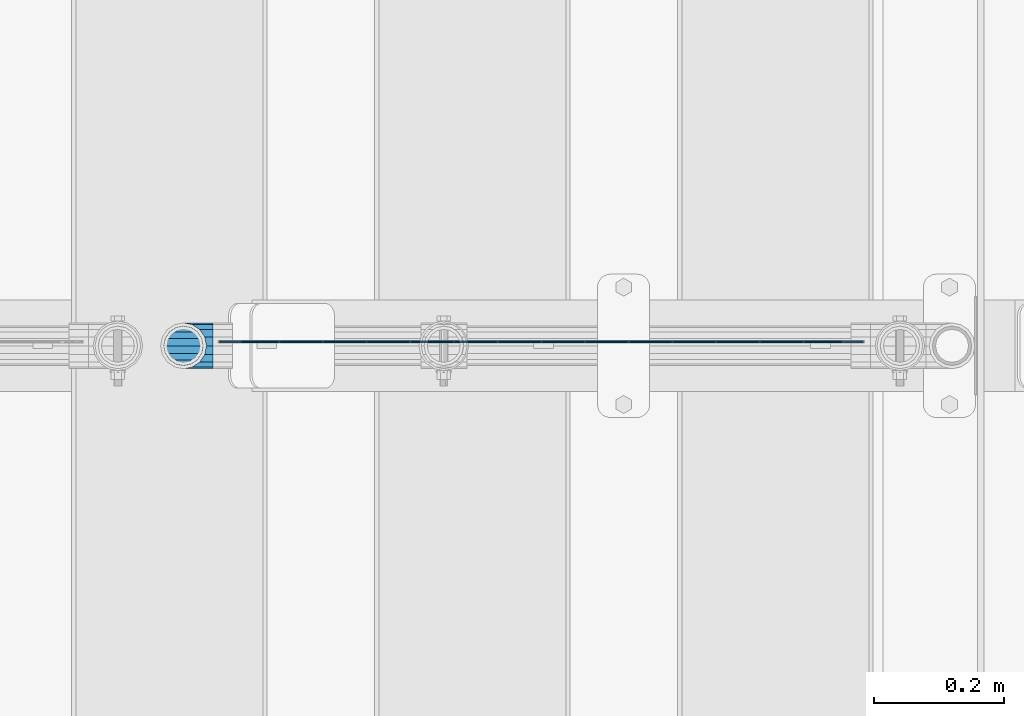
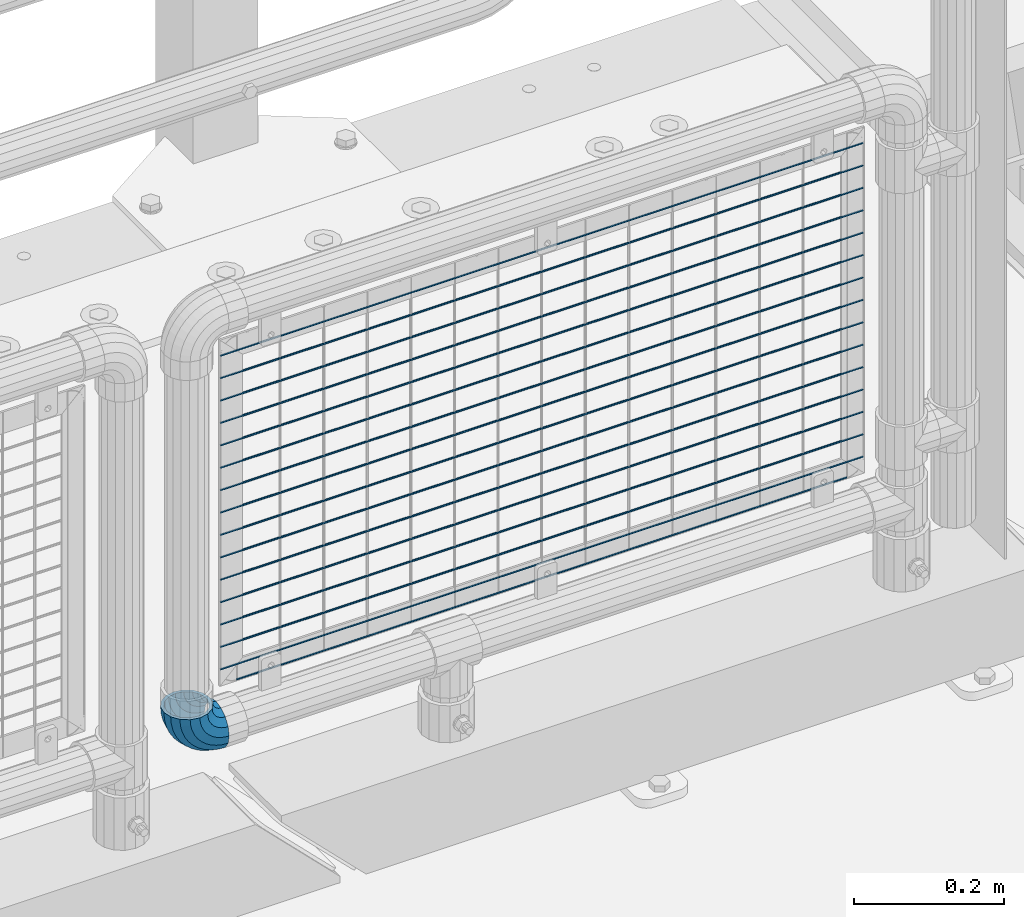
# One storey, part 168 of 247: 16 beams, 1 member.
"""IFC2X3 building model written with IfcOpenShell, lengths in millimetres."""

from ifc_helpers import new_model, si_unit, frame, origin_with_axes, place, context, subcontext, project, spatial, faceted_brep, material, type_object, element, save


model = new_model("IFC2X3")

# Units and contexts
model_context = context("Model", 3, precision=1e-05, world=origin_with_axes())
body_context = subcontext(model_context, "Body", "Model", "MODEL_VIEW")
ifc_project = project(units=[si_unit("LENGTHUNIT", "METRE", prefix="MILLI"), si_unit("AREAUNIT", "SQUARE_METRE"), si_unit("VOLUMEUNIT", "CUBIC_METRE"), si_unit("MASSUNIT", "GRAM", prefix="KILO"), si_unit("TIMEUNIT", "SECOND"), si_unit("PLANEANGLEUNIT", "RADIAN"), si_unit("SOLIDANGLEUNIT", "STERADIAN"), si_unit("THERMODYNAMICTEMPERATUREUNIT", "DEGREE_CELSIUS"), si_unit("LUMINOUSINTENSITYUNIT", "LUMEN")], contexts=[model_context])

# Site, building, storey
site_placement = place(None, origin_with_axes())
site = spatial("IfcSite", under=ifc_project, at=site_placement, CompositionType="ELEMENT")
building_placement = place(site_placement, origin_with_axes())
building = spatial("IfcBuilding", under=site, at=building_placement, Name="Standard", CompositionType="ELEMENT")
storey_placement = place(building_placement, origin_with_axes())
storey = spatial("IfcBuildingStorey", under=building, at=storey_placement, Name="Undefined", CompositionType="ELEMENT", Elevation=0.0)

# Member
ifc_material = material(Name="Misc_Undefined")
member_type = type_object("IfcMemberType", PredefinedType="NOTDEFINED")
member_placement = place(storey_placement, frame((15121.61, 7664.5, 343.170000000002), z_axis=(-0.707106773186475, 4.52999999771556e-07, -0.707106789186475), x_axis=(0.707106845186484, -4.15000000539602e-07, -0.707106717186484)))
element("IfcMember", 1, at=member_placement, inside=storey, type_object=member_type, material=ifc_material, context=body_context, shape_type="Brep", body=[
    faceted_brep([(0.0, -35.1499999999996, 0.0), (9.51152146007007, -32.4743655677721, -9.51152146007007), (13.2759578763416, -32.4743655677721, -6.29638902527768), (5.36946880023424, -35.1499999999996, 4.58595959347804), (17.5750000000007, -24.8548033587067, -17.5750000000007), (19.9787556631127, -24.8548033587067, -15.5219987155633), (22.9628441077039, -13.4513226476329, -22.962844107702), (24.4574219585265, -13.4513226476329, -21.6863540323957), (24.8548033587067, 0.0, -24.8548033587067), (26.0301204183143, 0.0, -23.8509877588021), (22.9628441077039, 13.4513226476329, -22.962844107702), (24.4574219585265, 13.4513226476329, -21.6863540323957), (17.5750000000007, 24.8548033587067, -17.5750000000007), (19.9787556631127, 24.8548033587067, -15.5219987155633), (9.51152146007007, 32.4743655677721, -9.51152146007007), (13.2759578763416, 32.4743655677721, -6.29638902527768), (0.0, 35.1499999999996, 0.0), (5.36946880023424, 35.1499999999996, 4.58595959347804), (-9.51152146007007, 32.4743655677721, 9.51152146007007), (-2.53702027587133, 32.4743655677721, 15.4683082122338), (-17.5749999999989, 24.8548033587067, 17.5749999999989), (-9.23981806264237, 24.8548033587067, 24.6939179025194), (-22.962844107702, 13.4513226476329, 22.962844107702), (-13.718484358058, 13.4513226476329, 30.8582732193499), (-24.8548033587067, 0.0, 24.8548033587067), (-15.2911828178458, 0.0, 33.0229069457564), (-22.962844107702, -13.4513226476329, 22.962844107702), (-13.718484358058, -13.4513226476329, 30.8582732193499), (-17.5749999999989, -24.8548033587067, 17.5749999999989), (-9.23981806264237, -24.8548033587067, 24.6939179025194), (-9.51152146007007, -32.4743655677721, 9.51152146007007), (-2.53702027587133, -32.4743655677721, 15.4683082122338), (0.0, -30.3500000000004, 0.0), (-8.21265081971796, -28.0397438117179, 8.21265081971796), (-1.45732902223608, -28.0397438117179, 13.9822406910371), (5.36946880023424, -30.3500000000004, 4.58595959347804), (-15.1749999999993, -21.4606908090118, 15.1749999999993), (-7.24480876131202, -21.4606908090118, 21.948023168994), (-19.8270929919981, -11.6144421722802, 19.827092992), (-11.1118790903529, -11.6144421722802, 27.2705888550772), (-21.4606908090118, 0.0, 21.4606908090118), (-12.4698136068437, 0.0, 29.139625372758), (-19.8270929919981, 11.6144421722802, 19.827092992), (-11.1118790903529, 11.6144421722802, 27.2705888550772), (-15.1749999999993, 21.4606908090118, 15.1749999999993), (-7.24480876131202, 21.4606908090118, 21.948023168994), (-8.21265081971796, 28.0397438117179, 8.21265081971796), (-1.45732902223608, 28.0397438117179, 13.9822406910371), (0.0, 30.3500000000004, 0.0), (5.36946880023424, 30.3500000000004, 4.58595959347804), (8.21265081971978, 28.0397438117179, -8.21265081971796), (12.1962666227046, 28.0397438117179, -4.81032150408282), (15.1750000000011, 21.4606908090118, -15.1750000000011), (17.9837463617787, 21.4606908090118, -12.776103982038), (19.827092992, 11.6144421722802, -19.827092992), (21.8508166908214, 11.6144421722802, -18.0986696681211), (21.4606908090118, 0.0, -21.4606908090118), (23.2087512073122, 0.0, -19.9677061858038), (19.827092992, -11.6144421722802, -19.827092992), (21.8508166908214, -11.6144421722802, -18.0986696681211), (15.1750000000011, -21.4606908090118, -15.1750000000011), (17.9837463617787, -21.4606908090118, -12.776103982038), (8.21265081971978, -28.0397438117179, -8.21265081971796), (12.1962666227046, -28.0397438117179, -4.81032150408282), (17.4970053560719, -32.4743655677721, -3.70972780292141), (11.3902326651169, -35.1499999999996, 8.27548843508157), (22.6740772628636, -24.8548033587067, -13.8703035149447), (26.1332861179544, -13.4513226476329, -20.6593831546816), (27.347998730962, 0.0, -23.0433908901377), (26.1332861179544, 13.4513226476329, -20.6593831546816), (22.6740772628636, 24.8548033587067, -13.8703035149447), (17.4970053560719, 32.4743655677721, -3.70972780292141), (11.3902326651169, 35.1499999999996, 8.27548843508157), (5.28345997416, 32.4743655677721, 20.2607046730845), (0.106388067368243, 24.8548033587067, 30.4212803851096), (-3.3528207877207, 13.4513226476329, 37.2103600248429), (-4.56753340072828, 0.0, 39.5943677603027), (-3.3528207877207, -13.4513226476329, 37.2103600248429), (0.106388067368243, -24.8548033587067, 30.4212803851096), (5.28345997416, -32.4743655677721, 20.2607046730845), (6.11738625912767, -28.0397438117179, 18.6240321853929), (11.3902326651169, -30.3500000000004, 8.27548843508157), (1.64728291997744, -21.4606908090118, 27.3971039594999), (-1.33954464053386, -11.6144421722802, 33.2590831078905), (-2.38837900197905, 0.0, 35.3175364441977), (-1.33954464053386, 11.6144421722802, 33.2590831078905), (1.64728291997744, 21.4606908090118, 27.3971039594999), (6.11738625912767, 28.0397438117179, 18.6240321853929), (11.3902326651169, 30.3500000000004, 8.27548843508157), (16.663079071106, 28.0397438117179, -2.07305531522979), (21.1331824102544, 21.4606908090118, -10.8461270893367), (24.1200099707676, 11.6144421722802, -16.7081062377292), (25.1688443322109, 0.0, -18.7665595740345), (24.1200099707676, -11.6144421722802, -16.7081062377292), (21.1331824102544, -21.4606908090118, -10.8461270893367), (16.663079071106, -28.0397438117179, -2.07305531522979), (22.0707277014626, -32.4743655677721, -1.81522997693355), (17.9140404065238, -35.1499999999996, 10.9777380798878), (25.5945970362118, -24.8548033587067, -12.6605846156472), (27.9491712485105, -13.4513226476329, -19.9072189058952), (28.7759877588032, 0.0, -22.4518984678889), (27.9491712485105, 13.4513226476329, -19.9072189058952), (25.5945970362118, 24.8548033587067, -12.6605846156472), (22.0707277014626, 32.4743655677721, -1.81522997693355), (17.9140404065238, 35.1499999999996, 10.9777380798878), (13.757353111585, 32.4743655677721, 23.7707061367073), (10.2334837768358, 24.8548033587067, 34.6160607754209), (7.87890956453703, 13.4513226476329, 41.8626950656671), (7.05209305424432, 0.0, 44.4073746276608), (7.87890956453703, -13.4513226476329, 41.8626950656671), (10.2334837768358, -24.8548033587067, 34.6160607754209), (13.757353111585, -32.4743655677721, 23.7707061367073), (14.3249803951039, -28.0397438117179, 22.0237289909692), (17.9140404065238, -30.3500000000004, 10.9777380798878), (11.2823222355109, -21.4606908090118, 31.3880679179929), (9.24928305078174, -11.6144421722802, 37.6451191472679), (8.53537462724307, 0.0, 39.8423033494455), (9.24928305078174, 11.6144421722802, 37.6451191472679), (11.2823222355109, 21.4606908090118, 31.3880679179929), (14.3249803951039, 28.0397438117179, 22.0237289909692), (17.9140404065238, 30.3500000000004, 10.9777380798878), (21.5031004179418, 28.0397438117179, -0.0682528311936039), (24.5457585775348, 21.4606908090118, -9.43259175821731), (26.578797762264, 11.6144421722802, -15.6896429874942), (27.2927061858027, 0.0, -17.8868271896699), (26.578797762264, -11.6144421722802, -15.6896429874942), (24.5457585775348, -21.4606908090118, -9.43259175821731), (21.5031004179418, -28.0397438117179, -0.0682528311936039), (26.884504689051, -32.4743655677721, -0.65954437126311), (24.7802542265854, -35.1499999999996, 12.6261701733856), (28.6684020936846, -24.8548033587067, -11.9226293117936), (29.8603642317012, -13.4513226476329, -19.4483820661262), (30.2789256727501, 0.0, -22.0910749985342), (29.8603642317012, 13.4513226476329, -19.4483820661262), (28.6684020936846, 24.8548033587067, -11.9226293117936), (26.884504689051, 32.4743655677721, -0.65954437126311), (24.7802542265854, 35.1499999999996, 12.6261701733856), (22.6760037641197, 32.4743655677721, 25.9118847180362), (20.8921063594862, 24.8548033587067, 37.1749696585666), (19.7001442214696, 13.4513226476329, 44.7007224128993), (19.2815827804206, 0.0, 47.3434153453054), (19.7001442214696, -13.4513226476329, 44.7007224128993), (20.8921063594862, -24.8548033587067, 37.1749696585666), (22.6760037641197, -32.4743655677721, 25.9118847180362), (22.9633551786228, -28.0397438117179, 24.097619289465), (24.7802542265854, -30.3500000000004, 12.6261701733856), (21.4230625404816, -21.4606908090118, 33.8226442665655), (20.3938719035341, -11.6144421722802, 40.3206982094944), (20.0324682126138, 0.0, 42.6025113104479), (20.3938719035341, 11.6144421722802, 40.3206982094944), (21.4230625404816, 21.4606908090118, 33.8226442665655), (22.9633551786228, 28.0397438117179, 24.097619289465), (24.7802542265854, 30.3500000000004, 12.6261701733856), (26.5971532745461, 28.0397438117179, 1.15472105730987), (28.1374459126855, 21.4606908090118, -8.5703039197906), (29.1666365496367, 11.6144421722802, -15.0683578627213), (29.5280402405569, 0.0, -17.3501709636766), (29.1666365496367, -11.6144421722802, -15.0683578627213), (28.1374459126855, -21.4606908090118, -8.5703039197906), (26.5971532745461, -28.0397438117179, 1.15472105730987), (31.8198051533964, -32.4743655677721, -0.271127801028342), (31.8198051533946, -35.1499999999996, 13.1801948466054), (31.8198051533964, -24.8548033587067, -11.6746085121031), (31.8198051533964, -13.4513226476329, -19.2941707211648), (31.8198051533964, 0.0, -21.969805153396), (31.8198051533964, 13.4513226476329, -19.2941707211648), (31.8198051533964, 24.8548033587067, -11.6746085121031), (31.8198051533964, 32.4743655677721, -0.271127801028342), (31.8198051533946, 35.1499999999996, 13.1801948466054), (31.8198051533946, 32.4743655677721, 26.6315174942392), (31.8198051533946, 24.8548033587067, 38.0349982053121), (31.8198051533964, 13.4513226476329, 45.6545604143757), (31.8198051533964, 0.0, 48.3301948466033), (31.8198051533964, -13.4513226476329, 45.6545604143757), (31.8198051533946, -24.8548033587067, 38.0349982053121), (31.8198051533946, -32.4743655677721, 26.6315174942392), (31.8198051533964, -28.0397438117179, 24.7946370188838), (31.8198051533946, -30.3500000000004, 13.1801948466054), (31.8198051533964, -21.4606908090118, 34.6408856556172), (31.8198051533946, -11.6144421722802, 41.2199386583234), (31.8198051533964, 0.0, 43.530194846604), (31.8198051533946, 11.6144421722802, 41.2199386583234), (31.8198051533964, 21.4606908090118, 34.6408856556172), (31.8198051533964, 28.0397438117179, 24.7946370188838), (31.8198051533946, 30.3500000000004, 13.1801948466054), (31.8198051533964, 28.0397438117179, 1.56575267432345), (31.8198051533964, 21.4606908090118, -8.28049596240635), (31.8198051533946, 11.6144421722802, -14.8595489651125), (31.8198051533964, 0.0, -17.1698051533949), (31.8198051533946, -11.6144421722802, -14.8595489651125), (31.8198051533964, -21.4606908090118, -8.28049596240635), (31.8198051533964, -28.0397438117179, 1.56575267432345), (36.7551056177399, -32.4743655677721, -0.659544371264928), (38.8593560802055, -35.1499999999996, 12.6261701733874), (34.9712082131082, -24.8548033587067, -11.9226293117936), (33.7792460750934, -13.4513226476329, -19.4483820661262), (33.3606846340426, 0.0, -22.0910749985342), (33.7792460750934, 13.4513226476329, -19.4483820661262), (34.9712082131082, 24.8548033587067, -11.9226293117936), (36.7551056177399, 32.4743655677721, -0.659544371264928), (38.8593560802055, 35.1499999999996, 12.6261701733874), (40.963606542673, 32.4743655677721, 25.9118847180362), (42.7475039473047, 24.8548033587067, 37.1749696585666), (43.9394660853195, 13.4513226476329, 44.7007224128993), (44.3580275263703, 0.0, 47.3434153453054), (43.9394660853195, -13.4513226476329, 44.7007224128993), (42.7475039473047, -24.8548033587067, 37.1749696585666), (40.963606542673, -32.4743655677721, 25.9118847180362), (40.6762551281663, -28.0397438117179, 24.097619289465), (38.8593560802055, -30.3500000000004, 12.6261701733874), (42.2165477663093, -21.4606908090118, 33.8226442665637), (43.2457384032587, -11.6144421722802, 40.3206982094925), (43.6071420941771, 0.0, 42.6025113104497), (43.2457384032587, 11.6144421722802, 40.3206982094925), (42.2165477663093, 21.4606908090118, 33.8226442665637), (40.6762551281663, 28.0397438117179, 24.097619289465), (38.8593560802055, 30.3500000000004, 12.6261701733874), (37.0424570322448, 28.0397438117179, 1.15472105730805), (35.5021643941036, 21.4606908090118, -8.5703039197906), (34.4729737571543, 11.6144421722802, -15.0683578627213), (34.1115700662358, 0.0, -17.3501709636766), (34.4729737571543, -11.6144421722802, -15.0683578627213), (35.5021643941036, -21.4606908090118, -8.5703039197906), (37.0424570322448, -28.0397438117179, 1.15472105730805), (41.5688826053301, -32.4743655677721, -1.81522997693355), (45.725569900269, -35.1499999999996, 10.9777380798878), (38.045013270581, -24.8548033587067, -12.6605846156453), (35.6904390582822, -13.4513226476329, -19.9072189058934), (34.8636225479895, 0.0, -22.4518984678889), (35.6904390582822, 13.4513226476329, -19.9072189058934), (38.045013270581, 24.8548033587067, -12.6605846156453), (41.5688826053301, 32.4743655677721, -1.81522997693355), (45.725569900269, 35.1499999999996, 10.9777380798878), (49.8822571952078, 32.4743655677721, 23.7707061367073), (53.406126529957, 24.8548033587067, 34.6160607754209), (55.7607007422539, 13.4513226476329, 41.8626950656671), (56.5875172525484, 0.0, 44.4073746276608), (55.7607007422539, -13.4513226476329, 41.8626950656671), (53.406126529957, -24.8548033587067, 34.6160607754209), (49.8822571952078, -32.4743655677721, 23.7707061367073), (49.3146299116888, -28.0397438117179, 22.0237289909674), (45.725569900269, -30.3500000000004, 10.9777380798878), (52.35728807128, -21.4606908090118, 31.3880679179929), (54.3903272560092, -11.6144421722802, 37.6451191472679), (55.1042356795479, 0.0, 39.8423033494455), (54.3903272560092, 11.6144421722802, 37.6451191472679), (52.35728807128, 21.4606908090118, 31.3880679179929), (49.3146299116888, 28.0397438117179, 22.0237289909674), (45.725569900269, 30.3500000000004, 10.9777380798878), (42.1365098888491, 28.0397438117179, -0.0682528311936039), (39.0938517292579, 21.4606908090118, -9.43259175821913), (37.0608125445287, 11.6144421722802, -15.6896429874942), (36.3469041209901, 0.0, -17.8868271896699), (37.0608125445287, -11.6144421722802, -15.6896429874942), (39.0938517292579, -21.4606908090118, -9.43259175821913), (42.1365098888491, -28.0397438117179, -0.0682528311936039), (46.1426049507172, -32.4743655677721, -3.70972780292141), (52.2493776416759, -35.1499999999996, 8.27548843508157), (40.9655330439273, -24.8548033587067, -13.8703035149447), (37.5063241888383, -13.4513226476329, -20.6593831546816), (36.2916115758308, 0.0, -23.0433908901396), (37.5063241888383, 13.4513226476329, -20.6593831546816), (40.9655330439273, 24.8548033587067, -13.8703035149447), (46.1426049507172, 32.4743655677721, -3.70972780292141), (52.2493776416759, 35.1499999999996, 8.27548843508157), (58.3561503326328, 32.4743655677721, 20.2607046730845), (63.5332222394227, 24.8548033587067, 30.4212803851078), (66.9924310945134, 13.4513226476329, 37.2103600248447), (68.207143707521, 0.0, 39.5943677603027), (66.9924310945134, -13.4513226476329, 37.2103600248447), (63.5332222394227, -24.8548033587067, 30.4212803851078), (58.3561503326328, -32.4743655677721, 20.2607046730845), (57.5222240476651, -28.0397438117179, 18.6240321853929), (52.2493776416759, -30.3500000000004, 8.27548843508157), (61.9923273868153, -21.4606908090118, 27.3971039594999), (64.9791549473266, -11.6144421722802, 33.2590831078905), (66.0279893087718, 0.0, 35.3175364441995), (64.9791549473266, 11.6144421722802, 33.2590831078905), (61.9923273868153, 21.4606908090118, 27.3971039594999), (57.5222240476651, 28.0397438117179, 18.6240321853929), (52.2493776416759, 30.3500000000004, 8.27548843508157), (46.9765312356867, 28.0397438117179, -2.07305531522979), (42.5064278965383, 21.4606908090118, -10.8461270893367), (39.5196003360252, 11.6144421722802, -16.7081062377292), (38.47076597458, 0.0, -18.7665595740345), (39.5196003360252, -11.6144421722802, -16.7081062377292), (42.5064278965383, -21.4606908090118, -10.8461270893367), (46.9765312356867, -28.0397438117179, -2.07305531522979), (50.3636524304511, -32.4743655677721, -6.29638902527768), (58.2701415065567, -35.1499999999996, 4.58595959347804), (43.6608546436782, -24.8548033587067, -15.5219987155633), (39.1821883482662, -13.4513226476329, -21.6863540323939), (37.6094898884767, 0.0, -23.8509877588021), (39.1821883482662, 13.4513226476329, -21.6863540323939), (43.6608546436782, 24.8548033587067, -15.5219987155633), (50.3636524304511, 32.4743655677721, -6.29638902527768), (58.2701415065567, 35.1499999999996, 4.58595959347804), (66.1766305826623, 32.4743655677721, 15.4683082122338), (72.8794283694351, 24.8548033587067, 24.6939179025212), (77.3580946648472, 13.4513226476329, 30.8582732193499), (78.9307931246385, 0.0, 33.0229069457564), (77.3580946648472, -13.4513226476329, 30.8582732193499), (72.8794283694351, -24.8548033587067, 24.6939179025212), (66.1766305826623, -32.4743655677721, 15.4683082122338), (65.096939329027, -28.0397438117179, 13.9822406910371), (58.2701415065567, -30.3500000000004, 4.58595959347804), (70.8844190681029, -21.4606908090118, 21.948023168994), (74.7514893971438, -11.6144421722802, 27.2705888550772), (76.1094239136346, 0.0, 29.139625372758), (74.7514893971438, 11.6144421722802, 27.2705888550772), (70.8844190681029, 21.4606908090118, 21.948023168994), (65.096939329027, 28.0397438117179, 13.9822406910371), (58.2701415065567, 30.3500000000004, 4.58595959347804), (51.4433436840882, 28.0397438117179, -4.810321504081), (45.6558639450104, 21.4606908090118, -12.776103982038), (41.7887936159714, 11.6144421722802, -18.0986696681211), (40.4308590994806, 0.0, -19.9677061858019), (41.7887936159714, -11.6144421722802, -18.0986696681211), (45.6558639450104, -21.4606908090118, -12.776103982038), (51.4433436840882, -28.0397438117179, -4.810321504081), (54.1280888467209, -32.4743655677721, -9.51152146007007), (63.6396103067891, -35.1499999999996, 0.0), (46.0646103067902, -24.8548033587067, -17.5750000000007), (40.6767661990871, -13.4513226476329, -22.962844107702), (38.7848069480824, 0.0, -24.8548033587067), (40.6767661990871, 13.4513226476329, -22.962844107702), (46.0646103067902, 24.8548033587067, -17.5750000000007), (54.1280888467209, 32.4743655677721, -9.51152146007007), (63.6396103067891, 35.1499999999996, 0.0), (73.1511317668592, 32.4743655677721, 9.51152146007007), (81.2146103067898, 24.8548033587067, 17.5750000000007), (86.602454414493, 13.4513226476329, 22.962844107702), (88.4944136654976, 0.0, 24.8548033587067), (86.602454414493, -13.4513226476329, 22.962844107702), (81.2146103067898, -24.8548033587067, 17.5750000000007), (73.1511317668592, -32.4743655677721, 9.51152146007007), (71.8522611265089, -28.0397438117179, 8.21265081971796), (63.6396103067891, -30.3500000000004, 0.0), (78.8146103067902, -21.4606908090118, 15.1749999999993), (83.4667032987891, -11.6144421722802, 19.8270929919981), (85.1003011158009, 0.0, 21.4606908090118), (83.4667032987891, 11.6144421722802, 19.8270929919981), (78.8146103067902, 21.4606908090118, 15.1749999999993), (71.8522611265089, 28.0397438117179, 8.21265081971796), (63.6396103067891, 30.3500000000004, 0.0), (55.4269594870711, 28.0397438117179, -8.21265081971796), (48.4646103067898, 21.4606908090118, -15.1749999999993), (43.812517314791, 11.6144421722802, -19.8270929919981), (42.1789194977791, 0.0, -21.4606908090118), (43.812517314791, -11.6144421722802, -19.8270929919981), (48.4646103067898, -21.4606908090118, -15.1749999999993), (55.4269594870711, -28.0397438117179, -8.21265081971796)], [[[0, 1, 2, 3]], [[1, 4, 5, 2]], [[4, 6, 7, 5]], [[6, 8, 9, 7]], [[8, 10, 11, 9]], [[10, 12, 13, 11]], [[12, 14, 15, 13]], [[14, 16, 17, 15]], [[16, 18, 19, 17]], [[18, 20, 21, 19]], [[20, 22, 23, 21]], [[22, 24, 25, 23]], [[24, 26, 27, 25]], [[26, 28, 29, 27]], [[28, 30, 31, 29]], [[30, 0, 3, 31]], [[32, 33, 34, 35]], [[33, 36, 37, 34]], [[36, 38, 39, 37]], [[38, 40, 41, 39]], [[40, 42, 43, 41]], [[42, 44, 45, 43]], [[44, 46, 47, 45]], [[46, 48, 49, 47]], [[48, 50, 51, 49]], [[50, 52, 53, 51]], [[52, 54, 55, 53]], [[54, 56, 57, 55]], [[56, 58, 59, 57]], [[58, 60, 61, 59]], [[60, 62, 63, 61]], [[62, 32, 35, 63]], [[30, 28, 26, 24, 22, 20, 18, 16, 14, 12, 10, 8, 6, 4, 1, 0], [62, 60, 58, 56, 54, 52, 50, 48, 46, 44, 42, 40, 38, 36, 33, 32]], [[3, 2, 64, 65]], [[2, 5, 66, 64]], [[5, 7, 67, 66]], [[7, 9, 68, 67]], [[9, 11, 69, 68]], [[11, 13, 70, 69]], [[13, 15, 71, 70]], [[15, 17, 72, 71]], [[17, 19, 73, 72]], [[19, 21, 74, 73]], [[21, 23, 75, 74]], [[23, 25, 76, 75]], [[25, 27, 77, 76]], [[27, 29, 78, 77]], [[29, 31, 79, 78]], [[31, 3, 65, 79]], [[35, 34, 80, 81]], [[34, 37, 82, 80]], [[37, 39, 83, 82]], [[39, 41, 84, 83]], [[41, 43, 85, 84]], [[43, 45, 86, 85]], [[45, 47, 87, 86]], [[47, 49, 88, 87]], [[49, 51, 89, 88]], [[51, 53, 90, 89]], [[53, 55, 91, 90]], [[55, 57, 92, 91]], [[57, 59, 93, 92]], [[59, 61, 94, 93]], [[61, 63, 95, 94]], [[63, 35, 81, 95]], [[65, 64, 96, 97]], [[64, 66, 98, 96]], [[66, 67, 99, 98]], [[67, 68, 100, 99]], [[68, 69, 101, 100]], [[69, 70, 102, 101]], [[70, 71, 103, 102]], [[71, 72, 104, 103]], [[72, 73, 105, 104]], [[73, 74, 106, 105]], [[74, 75, 107, 106]], [[75, 76, 108, 107]], [[76, 77, 109, 108]], [[77, 78, 110, 109]], [[78, 79, 111, 110]], [[79, 65, 97, 111]], [[81, 80, 112, 113]], [[80, 82, 114, 112]], [[82, 83, 115, 114]], [[83, 84, 116, 115]], [[84, 85, 117, 116]], [[85, 86, 118, 117]], [[86, 87, 119, 118]], [[87, 88, 120, 119]], [[88, 89, 121, 120]], [[89, 90, 122, 121]], [[90, 91, 123, 122]], [[91, 92, 124, 123]], [[92, 93, 125, 124]], [[93, 94, 126, 125]], [[94, 95, 127, 126]], [[95, 81, 113, 127]], [[97, 96, 128, 129]], [[96, 98, 130, 128]], [[98, 99, 131, 130]], [[99, 100, 132, 131]], [[100, 101, 133, 132]], [[101, 102, 134, 133]], [[102, 103, 135, 134]], [[103, 104, 136, 135]], [[104, 105, 137, 136]], [[105, 106, 138, 137]], [[106, 107, 139, 138]], [[107, 108, 140, 139]], [[108, 109, 141, 140]], [[109, 110, 142, 141]], [[110, 111, 143, 142]], [[111, 97, 129, 143]], [[113, 112, 144, 145]], [[112, 114, 146, 144]], [[114, 115, 147, 146]], [[115, 116, 148, 147]], [[116, 117, 149, 148]], [[117, 118, 150, 149]], [[118, 119, 151, 150]], [[119, 120, 152, 151]], [[120, 121, 153, 152]], [[121, 122, 154, 153]], [[122, 123, 155, 154]], [[123, 124, 156, 155]], [[124, 125, 157, 156]], [[125, 126, 158, 157]], [[126, 127, 159, 158]], [[127, 113, 145, 159]], [[129, 128, 160, 161]], [[128, 130, 162, 160]], [[130, 131, 163, 162]], [[131, 132, 164, 163]], [[132, 133, 165, 164]], [[133, 134, 166, 165]], [[134, 135, 167, 166]], [[135, 136, 168, 167]], [[136, 137, 169, 168]], [[137, 138, 170, 169]], [[138, 139, 171, 170]], [[139, 140, 172, 171]], [[140, 141, 173, 172]], [[141, 142, 174, 173]], [[142, 143, 175, 174]], [[143, 129, 161, 175]], [[145, 144, 176, 177]], [[144, 146, 178, 176]], [[146, 147, 179, 178]], [[147, 148, 180, 179]], [[148, 149, 181, 180]], [[149, 150, 182, 181]], [[150, 151, 183, 182]], [[151, 152, 184, 183]], [[152, 153, 185, 184]], [[153, 154, 186, 185]], [[154, 155, 187, 186]], [[155, 156, 188, 187]], [[156, 157, 189, 188]], [[157, 158, 190, 189]], [[158, 159, 191, 190]], [[159, 145, 177, 191]], [[161, 160, 192, 193]], [[160, 162, 194, 192]], [[162, 163, 195, 194]], [[163, 164, 196, 195]], [[164, 165, 197, 196]], [[165, 166, 198, 197]], [[166, 167, 199, 198]], [[167, 168, 200, 199]], [[168, 169, 201, 200]], [[169, 170, 202, 201]], [[170, 171, 203, 202]], [[171, 172, 204, 203]], [[172, 173, 205, 204]], [[173, 174, 206, 205]], [[174, 175, 207, 206]], [[175, 161, 193, 207]], [[177, 176, 208, 209]], [[176, 178, 210, 208]], [[178, 179, 211, 210]], [[179, 180, 212, 211]], [[180, 181, 213, 212]], [[181, 182, 214, 213]], [[182, 183, 215, 214]], [[183, 184, 216, 215]], [[184, 185, 217, 216]], [[185, 186, 218, 217]], [[186, 187, 219, 218]], [[187, 188, 220, 219]], [[188, 189, 221, 220]], [[189, 190, 222, 221]], [[190, 191, 223, 222]], [[191, 177, 209, 223]], [[193, 192, 224, 225]], [[192, 194, 226, 224]], [[194, 195, 227, 226]], [[195, 196, 228, 227]], [[196, 197, 229, 228]], [[197, 198, 230, 229]], [[198, 199, 231, 230]], [[199, 200, 232, 231]], [[200, 201, 233, 232]], [[201, 202, 234, 233]], [[202, 203, 235, 234]], [[203, 204, 236, 235]], [[204, 205, 237, 236]], [[205, 206, 238, 237]], [[206, 207, 239, 238]], [[207, 193, 225, 239]], [[209, 208, 240, 241]], [[208, 210, 242, 240]], [[210, 211, 243, 242]], [[211, 212, 244, 243]], [[212, 213, 245, 244]], [[213, 214, 246, 245]], [[214, 215, 247, 246]], [[215, 216, 248, 247]], [[216, 217, 249, 248]], [[217, 218, 250, 249]], [[218, 219, 251, 250]], [[219, 220, 252, 251]], [[220, 221, 253, 252]], [[221, 222, 254, 253]], [[222, 223, 255, 254]], [[223, 209, 241, 255]], [[225, 224, 256, 257]], [[224, 226, 258, 256]], [[226, 227, 259, 258]], [[227, 228, 260, 259]], [[228, 229, 261, 260]], [[229, 230, 262, 261]], [[230, 231, 263, 262]], [[231, 232, 264, 263]], [[232, 233, 265, 264]], [[233, 234, 266, 265]], [[234, 235, 267, 266]], [[235, 236, 268, 267]], [[236, 237, 269, 268]], [[237, 238, 270, 269]], [[238, 239, 271, 270]], [[239, 225, 257, 271]], [[241, 240, 272, 273]], [[240, 242, 274, 272]], [[242, 243, 275, 274]], [[243, 244, 276, 275]], [[244, 245, 277, 276]], [[245, 246, 278, 277]], [[246, 247, 279, 278]], [[247, 248, 280, 279]], [[248, 249, 281, 280]], [[249, 250, 282, 281]], [[250, 251, 283, 282]], [[251, 252, 284, 283]], [[252, 253, 285, 284]], [[253, 254, 286, 285]], [[254, 255, 287, 286]], [[255, 241, 273, 287]], [[257, 256, 288, 289]], [[256, 258, 290, 288]], [[258, 259, 291, 290]], [[259, 260, 292, 291]], [[260, 261, 293, 292]], [[261, 262, 294, 293]], [[262, 263, 295, 294]], [[263, 264, 296, 295]], [[264, 265, 297, 296]], [[265, 266, 298, 297]], [[266, 267, 299, 298]], [[267, 268, 300, 299]], [[268, 269, 301, 300]], [[269, 270, 302, 301]], [[270, 271, 303, 302]], [[271, 257, 289, 303]], [[273, 272, 304, 305]], [[272, 274, 306, 304]], [[274, 275, 307, 306]], [[275, 276, 308, 307]], [[276, 277, 309, 308]], [[277, 278, 310, 309]], [[278, 279, 311, 310]], [[279, 280, 312, 311]], [[280, 281, 313, 312]], [[281, 282, 314, 313]], [[282, 283, 315, 314]], [[283, 284, 316, 315]], [[284, 285, 317, 316]], [[285, 286, 318, 317]], [[286, 287, 319, 318]], [[287, 273, 305, 319]], [[289, 288, 320, 321]], [[288, 290, 322, 320]], [[290, 291, 323, 322]], [[291, 292, 324, 323]], [[292, 293, 325, 324]], [[293, 294, 326, 325]], [[294, 295, 327, 326]], [[295, 296, 328, 327]], [[296, 297, 329, 328]], [[297, 298, 330, 329]], [[298, 299, 331, 330]], [[299, 300, 332, 331]], [[300, 301, 333, 332]], [[301, 302, 334, 333]], [[302, 303, 335, 334]], [[303, 289, 321, 335]], [[305, 304, 336, 337]], [[304, 306, 338, 336]], [[306, 307, 339, 338]], [[307, 308, 340, 339]], [[308, 309, 341, 340]], [[309, 310, 342, 341]], [[310, 311, 343, 342]], [[311, 312, 344, 343]], [[312, 313, 345, 344]], [[313, 314, 346, 345]], [[314, 315, 347, 346]], [[315, 316, 348, 347]], [[316, 317, 349, 348]], [[317, 318, 350, 349]], [[318, 319, 351, 350]], [[319, 305, 337, 351]], [[322, 323, 324, 325, 326, 327, 328, 329, 330, 331, 332, 333, 334, 335, 321, 320], [338, 339, 340, 341, 342, 343, 344, 345, 346, 347, 348, 349, 350, 351, 337, 336]]]),
])

# Beams
beam_type = type_object("IfcBeamType", Name="D3", PredefinedType="NOTDEFINED")
for number, where, z_axis, x_axis in (
    (2, (15176.61, 7670.49998833461, 633.023), (0.0, 0.0, 1.0), (1.0, 0.0, 0.0)),
    (3, (15176.61, 7670.49998833846, 815.168), (0.0, 0.0, 1.0), (1.0, 0.0, 0.0)),
    (4, (15176.61, 7670.49998833538, 669.452), (0.0, 0.0, 1.0), (1.0, 0.0, 0.0)),
    (5, (15176.61, 7670.49998833384, 596.594000000001), (0.0, 0.0, 1.0), (1.0, 0.0, 0.0)),
    (6, (15176.61, 7670.49998833307, 560.165), (0.0, 0.0, 1.0), (1.0, 0.0, 0.0)),
    (7, (15176.61, 7670.49998833769, 778.739), (0.0, 0.0, 1.0), (1.0, 0.0, 0.0)),
    (8, (15176.61, 7670.4999883323, 523.736), (0.0, 0.0, 1.0), (1.0, 0.0, 0.0)),
    (9, (15176.61, 7670.49998833923, 851.597), (0.0, 0.0, 1.0), (1.0, 0.0, 0.0)),
    (10, (15176.61, 7670.49998833153, 487.307), (0.0, 0.0, 1.0), (1.0, 0.0, 0.0)),
    (11, (15176.61, 7670.49998833615, 705.881), (0.0, 0.0, 1.0), (1.0, 0.0, 0.0)),
    (12, (15176.61, 7670.49998833076, 450.878), (0.0, 0.0, 1.0), (1.0, 0.0, 0.0)),
    (13, (15176.61, 7670.49998834, 888.026), (0.0, 0.0, 1.0), (1.0, 0.0, 0.0)),
    (14, (15176.61, 7670.49998833692, 742.31), (0.0, 0.0, 1.0), (1.0, 0.0, 0.0)),
    (15, (15176.61, 7670.49998832999, 414.449), (0.0, 0.0, 1.0), (1.0, 0.0, 0.0)),
):
    element("IfcBeam", number, at=place(storey_placement, frame(where, z_axis=z_axis, x_axis=x_axis)), inside=storey, type_object=beam_type, material=ifc_material, ObjectType="D3", context=body_context, shape_type="Brep", body=[
        faceted_brep([(1.81898940354586e-12, -1.5, -5.6843418860808e-14), (0.0, -0.75, -1.29903810567703), (988.390000000245, -0.749999999999091, -1.29903810567669), (988.390000000245, -1.49999999999909, 0.0), (0.0, 0.75, -1.29903810567703), (988.390000000243, 0.750000000000909, -1.29903810567669), (1.81898940354586e-12, 1.5, -5.6843418860808e-14), (988.390000000243, 1.50000000000091, 0.0), (0.0, 0.75, 1.29903810567703), (988.390000000243, 0.750000000000909, 1.29903810567669), (0.0, -0.75, 1.29903810567703), (988.390000000245, -0.749999999999091, 1.29903810567669)], [[[0, 1, 2, 3]], [[1, 4, 5, 2]], [[4, 6, 7, 5]], [[6, 8, 9, 7]], [[8, 10, 11, 9]], [[10, 0, 3, 11]], [[5, 7, 9, 11, 3, 2]], [[10, 8, 6, 4, 1, 0]]]),
    ])
beam_1_placement = place(storey_placement, frame((15201.61, 7670.49998302432, 353.02), z_axis=(0.0, 0.0, 1.0), x_axis=(1.0, 0.0, 0.0)))
element("IfcBeam", 16, at=beam_1_placement, inside=storey, type_object=beam_type, material=ifc_material, ObjectType="D3", context=body_context, shape_type="Brep", body=[
    faceted_brep([(1.81898940354586e-12, -1.5, -5.6843418860808e-14), (0.0, -0.75, -1.29903810567703), (938.390000000096, -0.749999999999091, -1.29903810567669), (938.390000000096, -1.49999999999909, 0.0), (0.0, 0.75, -1.29903810567703), (938.390000000096, 0.750000000000909, -1.29903810567663), (1.81898940354586e-12, 1.5, -5.6843418860808e-14), (938.390000000096, 1.50000000000091, 0.0), (0.0, 0.75, 1.29903810567703), (938.390000000096, 0.750000000000909, 1.29903810567669), (0.0, -0.75, 1.29903810567703), (938.390000000096, -0.749999999999091, 1.29903810567669)], [[[0, 1, 2, 3]], [[1, 4, 5, 2]], [[4, 6, 7, 5]], [[6, 8, 9, 7]], [[8, 10, 11, 9]], [[10, 0, 3, 11]], [[5, 7, 9, 11, 3, 2]], [[10, 8, 6, 4, 1, 0]]]),
])
beam_2_placement = place(storey_placement, frame((15176.61, 7670.49998832922, 378.02), z_axis=(0.0, 0.0, 1.0), x_axis=(1.0, 0.0, 0.0)))
element("IfcBeam", 17, at=beam_2_placement, inside=storey, type_object=beam_type, material=ifc_material, ObjectType="D3", context=body_context, shape_type="Brep", body=[
    faceted_brep([(1.81898940354586e-12, -1.5, -5.6843418860808e-14), (0.0, -0.75, -1.29903810567703), (988.390000000245, -0.749999999999091, -1.29903810567669), (988.390000000245, -1.49999999999909, 0.0), (0.0, 0.75, -1.29903810567703), (988.390000000243, 0.750000000000909, -1.29903810567669), (1.81898940354586e-12, 1.5, -5.6843418860808e-14), (988.390000000243, 1.50000000000091, 0.0), (0.0, 0.75, 1.29903810567703), (988.390000000243, 0.750000000000909, 1.29903810567669), (0.0, -0.75, 1.29903810567703), (988.390000000245, -0.749999999999091, 1.29903810567669)], [[[0, 1, 2, 3]], [[1, 4, 5, 2]], [[4, 6, 7, 5]], [[6, 8, 9, 7]], [[8, 10, 11, 9]], [[10, 0, 3, 11]], [[5, 7, 9, 11, 3, 2]], [[10, 8, 6, 4, 1, 0]]]),
])

save(model, "model.ifc")
